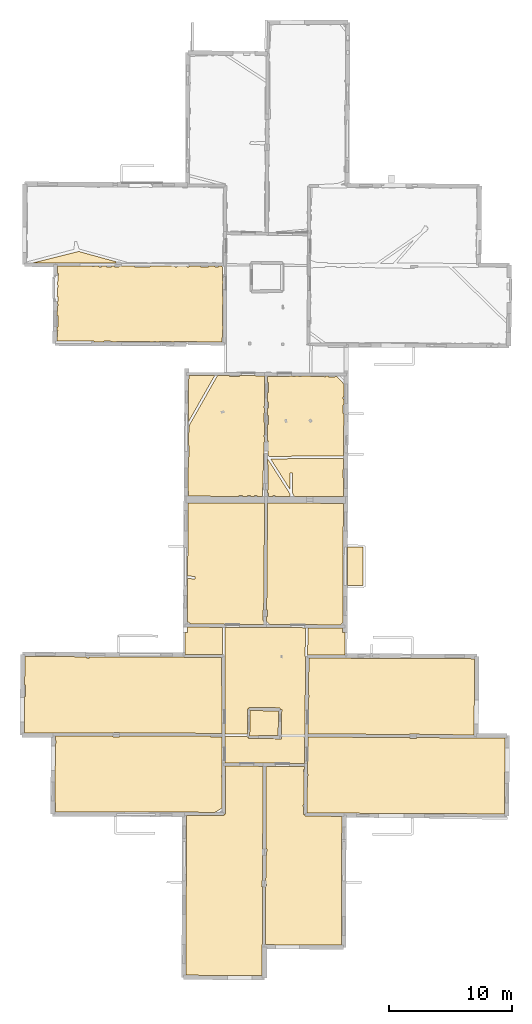
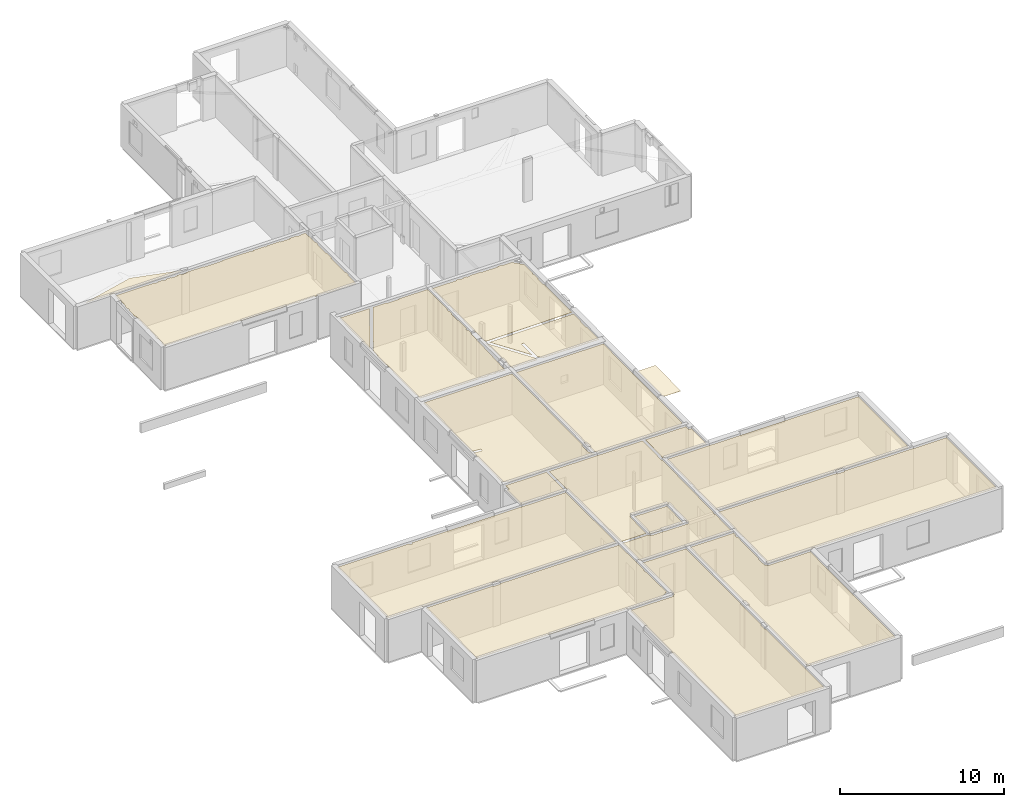
# One storey, part 12 of 17: 20 coverings.
"""IFC2X3 building model written with IfcOpenShell, lengths in metres."""

from ifc_helpers import new_model, entity, si_unit, converted_unit, derived_unit, direction, frame, origin, origin_with_axes, place, context, subcontext, project, spatial, polyline, outline, extrude, material, layer, layer_set, layer_usage, type_object, element, save


model = new_model("IFC2X3")

# Units and contexts
model_context = context("Model", 3, precision=1e-05, world=origin(), true_north=direction((0.0, 1.0)))
body_context = subcontext(model_context, "Body", "Model", "MODEL_VIEW")
ifc_project = project(units=[si_unit("LENGTHUNIT", "METRE"), si_unit("AREAUNIT", "SQUARE_METRE"), si_unit("VOLUMEUNIT", "CUBIC_METRE"), converted_unit("PLANEANGLEUNIT", "DEGREE", entity("IfcRatioMeasure", 0.0174532925199433), si_unit("PLANEANGLEUNIT", "RADIAN"), dimensions=[0, 0, 0, 0, 0, 0, 0]), si_unit("MASSUNIT", "GRAM", prefix="KILO"), derived_unit("MASSDENSITYUNIT", [(si_unit("MASSUNIT", "GRAM", prefix="KILO"), 1), (si_unit("LENGTHUNIT", "METRE"), -3)]), derived_unit("MOMENTOFINERTIAUNIT", [(si_unit("LENGTHUNIT", "METRE"), 4)]), si_unit("TIMEUNIT", "SECOND"), si_unit("FREQUENCYUNIT", "HERTZ"), si_unit("THERMODYNAMICTEMPERATUREUNIT", "DEGREE_CELSIUS"), derived_unit("THERMALTRANSMITTANCEUNIT", [(si_unit("MASSUNIT", "GRAM", prefix="KILO"), 1), (si_unit("THERMODYNAMICTEMPERATUREUNIT", "KELVIN"), -1), (si_unit("TIMEUNIT", "SECOND"), -3)]), derived_unit("VOLUMETRICFLOWRATEUNIT", [(si_unit("LENGTHUNIT", "METRE"), 3), (si_unit("TIMEUNIT", "SECOND"), -1)]), si_unit("ELECTRICCURRENTUNIT", "AMPERE"), si_unit("ELECTRICVOLTAGEUNIT", "VOLT"), si_unit("POWERUNIT", "WATT"), si_unit("FORCEUNIT", "NEWTON", prefix="KILO"), si_unit("ILLUMINANCEUNIT", "LUX"), si_unit("LUMINOUSFLUXUNIT", "LUMEN"), si_unit("LUMINOUSINTENSITYUNIT", "CANDELA"), derived_unit("USERDEFINED", [(si_unit("MASSUNIT", "GRAM", prefix="KILO"), -1), (si_unit("LENGTHUNIT", "METRE"), -2), (si_unit("TIMEUNIT", "SECOND"), 3), (si_unit("LUMINOUSFLUXUNIT", "LUMEN"), 1)]), derived_unit("LINEARVELOCITYUNIT", [(si_unit("LENGTHUNIT", "METRE"), 1), (si_unit("TIMEUNIT", "SECOND"), -1)]), si_unit("PRESSUREUNIT", "PASCAL"), derived_unit("USERDEFINED", [(si_unit("LENGTHUNIT", "METRE"), -2), (si_unit("MASSUNIT", "GRAM", prefix="KILO"), 1), (si_unit("TIMEUNIT", "SECOND"), -2)]), derived_unit("LINEARFORCEUNIT", [(si_unit("MASSUNIT", "GRAM", prefix="KILO"), 1), (si_unit("LENGTHUNIT", "METRE"), 1), (si_unit("TIMEUNIT", "SECOND"), -2), (si_unit("LENGTHUNIT", "METRE"), -1)]), derived_unit("PLANARFORCEUNIT", [(si_unit("MASSUNIT", "GRAM", prefix="KILO"), 1), (si_unit("LENGTHUNIT", "METRE"), 1), (si_unit("TIMEUNIT", "SECOND"), -2), (si_unit("LENGTHUNIT", "METRE"), -2)])], contexts=[model_context])

# Site, building, storey
placement = place(None, origin())
site = spatial("IfcSite", under=ifc_project, at=placement, CompositionType="ELEMENT")
building = spatial("IfcBuilding", under=site, at=placement, CompositionType="ELEMENT")
storey_placement = place(placement, frame((0.0, 0.0, 5.56662893295288)))
storey = spatial("IfcBuildingStorey", under=building, at=storey_placement, Name="Level 3", CompositionType="ELEMENT", Elevation=5.56662893295288)

# Coverings
ifc_material = material(Name="Covering default")
ifc_layer_1 = layer(ifc_material, 0.02)
ifc_layer_set_1 = layer_set([ifc_layer_1], Name="Covering : 20mm")
ifc_layer_usage_1 = layer_usage(ifc_layer_set_1, "AXIS3", "POSITIVE", 0.0)
covering_type_1 = type_object("IfcCoveringType", Name="Covering : 20mm", PredefinedType="CEILING")
covering_1_placement = place(placement, frame((0.0, 0.0, 8.5707950592041)))
element("IfcCovering", 1, at=covering_1_placement, inside=storey, type_object=covering_type_1, material=ifc_layer_usage_1, Name="Covering : 20mm", ObjectType="Covering : 20mm", PredefinedType="CEILING", context=body_context, shape_type="SweptSolid", body=[
    extrude(outline(polyline([(-0.158495903015137, 12.9272747039795), (2.870041847229, 12.9294729232788), (2.86995029449463, 13.0544738769531), (2.99994945526123, 13.0549507141113), (2.98575115203857, 16.9304695129395), (6.0559606552124, 16.915620803833), (6.01420116424561, 7.62759780883789), (5.95738506317139, 7.62850570678711), (5.94955539703369, 7.13856840133667), (6.01199817657471, 7.13757085800171), (5.98857402801514, 1.92784667015076), (5.98791980743408, -0.0800504088401794), (-0.209152221679688, -0.050336629152298), (-0.158495903015137, 12.9272747039795)])), origin_with_axes(), (0.0, 0.0, 1.0), 0.02),
])
ifc_layer_2 = layer(ifc_material, 0.02)
ifc_layer_set_2 = layer_set([ifc_layer_2], Name="Covering : 20mm")
ifc_layer_usage_2 = layer_usage(ifc_layer_set_2, "AXIS3", "POSITIVE", 0.0)
covering_type_2 = type_object("IfcCoveringType", Name="Covering : 20mm", PredefinedType="CEILING")
covering_2_placement = place(placement, frame((0.0, 0.0, 8.5707950592041)))
element("IfcCovering", 2, at=covering_2_placement, inside=storey, type_object=covering_type_2, material=ifc_layer_usage_2, Name="Covering : 20mm", ObjectType="Covering : 20mm", PredefinedType="CEILING", context=body_context, shape_type="SweptSolid", body=[
    extrude(outline(polyline([(6.27230358123779, 7.20511674880981), (6.32816600799561, 7.20514488220215), (6.32808399200439, 7.36514854431152), (6.27302265167236, 7.36512041091919), (6.28346347808838, 9.68734073638916), (6.35218334197998, 9.68637943267822), (6.35924625396729, 10.1913299560547), (6.28573513031006, 10.1923580169678), (6.31595706939697, 16.914363861084), (9.40763759613037, 16.8994083404541), (9.40445232391357, 16.6541633605957), (9.3533239364624, 16.6566944122314), (9.34342670440674, 16.456693649292), (9.40185070037842, 16.4538021087646), (9.3672456741333, 13.7889347076416), (9.31479549407959, 13.7866764068604), (9.34922695159912, 12.9871711730957), (9.45486354827881, 12.991720199585), (9.44913578033447, 12.9917945861816), (9.44857311248779, 12.8664751052856), (12.4514169692993, 12.8530235290527), (12.4169778823853, 2.39204859733582), (6.25081539154053, 2.42574691772461), (6.27230358123779, 7.20511674880981)])), origin_with_axes(), (0.0, 0.0, 1.0), 0.02),
])
ifc_layer_3 = layer(ifc_material, 0.02)
ifc_layer_set_3 = layer_set([ifc_layer_3], Name="Covering : 20mm")
ifc_layer_usage_3 = layer_usage(ifc_layer_set_3, "AXIS3", "POSITIVE", 0.0)
covering_type_3 = type_object("IfcCoveringType", Name="Covering : 20mm", PredefinedType="CEILING")
covering_3_placement = place(placement, frame((0.0, 0.0, 8.5707950592041)))
element("IfcCovering", 3, at=covering_3_placement, inside=storey, type_object=covering_type_3, material=ifc_layer_usage_3, Name="Covering : 20mm", ObjectType="Covering : 20mm", PredefinedType="CEILING", context=body_context, shape_type="SweptSolid", body=[
    extrude(outline(polyline([(9.65762615203857, 16.1268520355225), (9.71359539031982, 16.126880645752), (9.71351528167725, 16.2868804931641), (9.65970516204834, 16.2868518829346), (9.67087459564209, 17.1470699310303), (9.67087459564209, 17.1470699310303), (9.69874286651611, 19.293176651001), (17.9931602478027, 19.2454681396484), (17.9925880432129, 19.1877975463867), (18.5025634765625, 19.1827526092529), (18.5031547546387, 19.2425346374512), (23.3761177062988, 19.214506149292), (23.3761444091797, 19.2014865875244), (25.6997146606445, 19.2062892913818), (25.6643981933594, 13.0456771850586), (12.6374959945679, 13.1063585281372), (12.6374769210815, 13.1021928787231), (9.61852550506592, 13.1157159805298), (9.65762615203857, 16.1268520355225)])), origin_with_axes(), (0.0, 0.0, 1.0), 0.02),
])
ifc_layer_4 = layer(ifc_material, 0.02)
ifc_layer_set_4 = layer_set([ifc_layer_4], Name="Covering : 20mm")
ifc_layer_usage_4 = layer_usage(ifc_layer_set_4, "AXIS3", "POSITIVE", 0.0)
covering_type_4 = type_object("IfcCoveringType", Name="Covering : 20mm", PredefinedType="CEILING")
covering_4_placement = place(placement, frame((0.0, 0.0, 8.5707950592041)))
element("IfcCovering", 4, at=covering_4_placement, inside=storey, type_object=covering_type_4, material=ifc_layer_usage_4, Name="Covering : 20mm", ObjectType="Covering : 20mm", PredefinedType="CEILING", context=body_context, shape_type="SweptSolid", body=[
    extrude(outline(polyline([(-10.8086032867432, 18.7683277130127), (-10.7577590942383, 18.7663974761963), (-10.7478923797607, 19.0264015197754), (-10.807074546814, 19.0286464691162), (-10.8050508499146, 19.3731346130371), (-6.11005687713623, 19.3665676116943), (-6.1105260848999, 19.312816619873), (-5.59554576873779, 19.3083229064941), (-5.59504413604736, 19.3658466339111), (1.7731237411499, 19.3555374145508), (1.77196788787842, 19.3028144836426), (2.71713542938232, 19.2820587158203), (2.72483348846436, 17.1806201934814), (2.72483348846436, 17.1806201934814), (2.72837734222412, 16.2133026123047), (2.67355251312256, 16.2132740020752), (2.67364978790283, 16.0232753753662), (2.7290735244751, 16.0233039855957), (2.73818302154541, 13.5367527008057), (2.16902923583984, 13.1789646148682), (-10.7849082946777, 13.2056856155396), (-10.7852993011475, 13.9663791656494), (-10.8368139266968, 13.9663524627686), (-10.8086032867432, 18.7683277130127)])), origin_with_axes(), (0.0, 0.0, 1.0), 0.02),
])
ifc_layer_5 = layer(ifc_material, 0.02)
ifc_layer_set_5 = layer_set([ifc_layer_5], Name="Covering : 20mm")
ifc_layer_usage_5 = layer_usage(ifc_layer_set_5, "AXIS3", "POSITIVE", 0.0)
covering_type_5 = type_object("IfcCoveringType", Name="Covering : 20mm", PredefinedType="CEILING")
covering_5_placement = place(placement, frame((0.0, 0.0, 8.5707950592041)))
element("IfcCovering", 5, at=covering_5_placement, inside=storey, type_object=covering_type_5, material=ifc_layer_usage_5, Name="Covering : 20mm", ObjectType="Covering : 20mm", PredefinedType="CEILING", context=body_context, shape_type="SweptSolid", body=[
    extrude(outline(polyline([(2.95767498016357, 28.198522567749), (6.47996044158936, 28.1796741485596), (9.508376121521, 28.1634693145752), (9.47066974639893, 25.8293075561523), (9.52358341217041, 25.8284530639648), (9.4403600692749, 19.4194049835205), (9.381911277771, 19.419376373291), (9.38199901580811, 19.2467098236084), (9.43811893463135, 19.2467384338379), (9.41088390350342, 17.1493949890137), (6.05712795257568, 17.1656169891357), (6.05712795257568, 17.1656169891357), (2.98483562469482, 17.1804752349854), (2.97691249847412, 19.3432579040527), (4.77200603485107, 19.3406238555908), (4.77137660980225, 19.2836322784424), (4.87137126922607, 19.282527923584), (4.86987400054932, 19.1825389862061), (7.55145359039307, 19.1424236297607), (7.55444622039795, 19.3424015045166), (7.5374059677124, 19.3426570892334), (7.57736110687256, 21.5297183990479), (7.44738292694092, 21.5320930480957), (7.44945049285889, 21.6620769500732), (4.89870548248291, 21.7026386260986), (4.89663791656494, 21.5726547241211), (4.79664516448975, 21.5737571716309), (4.77421283721924, 19.5406188964844), (2.97618007659912, 19.5432567596436), (2.95058536529541, 26.5304126739502), (2.95767498016357, 28.198522567749)])), origin_with_axes(), (0.0, 0.0, 1.0), 0.02),
])
ifc_layer_6 = layer(ifc_material, 0.02)
ifc_layer_set_6 = layer_set([ifc_layer_6], Name="Covering : 20mm")
ifc_layer_usage_6 = layer_usage(ifc_layer_set_6, "AXIS3", "POSITIVE", 0.0)
covering_type_6 = type_object("IfcCoveringType", Name="Covering : 20mm", PredefinedType="CEILING")
covering_6_placement = place(placement, frame((0.0, 0.0, 8.5707950592041)))
element("IfcCovering", 6, at=covering_6_placement, inside=storey, type_object=covering_type_6, material=ifc_layer_usage_6, Name="Covering : 20mm", ObjectType="Covering : 20mm", PredefinedType="CEILING", context=body_context, shape_type="SweptSolid", body=[
    extrude(outline(polyline([(4.995192527771, 21.4410705566406), (7.31502437591553, 21.4041805267334), (7.27849864959717, 19.4048385620117), (5.69967746734619, 19.4292087554932), (5.69876575469971, 19.3701610565186), (4.97246265411377, 19.3810272216797), (4.995192527771, 21.4410705566406)])), origin_with_axes(), (0.0, 0.0, 1.0), 0.02),
])
ifc_layer_7 = layer(ifc_material, 0.02)
ifc_layer_set_7 = layer_set([ifc_layer_7], Name="Covering : 20mm")
ifc_layer_usage_7 = layer_usage(ifc_layer_set_7, "AXIS3", "POSITIVE", 0.0)
covering_type_7 = type_object("IfcCoveringType", Name="Covering : 20mm", PredefinedType="CEILING")
covering_7_placement = place(placement, frame((0.0, 0.0, 8.5707950592041)))
element("IfcCovering", 7, at=covering_7_placement, inside=storey, type_object=covering_type_7, material=ifc_layer_usage_7, Name="Covering : 20mm", ObjectType="Covering : 20mm", PredefinedType="CEILING", context=body_context, shape_type="SweptSolid", body=[
    extrude(outline(polyline([(9.74060344696045, 22.5168952941895), (9.80032253265381, 22.5169258117676), (9.80023097991943, 22.6969261169434), (9.74294185638428, 22.6968975067139), (9.78196620941162, 25.7021980285645), (23.2324485778809, 25.6460094451904), (23.1912422180176, 19.4655742645264), (18.7512435913086, 19.4911117553711), (18.7518501281738, 19.5415115356445), (17.9518432617188, 19.5510997772217), (17.9511795043945, 19.4957141876221), (9.70198726654053, 19.5431613922119), (9.74060344696045, 22.5168952941895)])), origin_with_axes(), (0.0, 0.0, 1.0), 0.02),
])
ifc_layer_8 = layer(ifc_material, 0.02)
ifc_layer_set_8 = layer_set([ifc_layer_8], Name="Covering : 20mm")
ifc_layer_usage_8 = layer_usage(ifc_layer_set_8, "AXIS3", "POSITIVE", 0.0)
covering_type_8 = type_object("IfcCoveringType", Name="Covering : 20mm", PredefinedType="CEILING")
covering_8_placement = place(placement, frame((0.0, 0.0, 8.5707950592041)))
element("IfcCovering", 8, at=covering_8_placement, inside=storey, type_object=covering_type_8, material=ifc_layer_usage_8, Name="Covering : 20mm", ObjectType="Covering : 20mm", PredefinedType="CEILING", context=body_context, shape_type="SweptSolid", body=[
    extrude(outline(polyline([(-13.304892539978, 22.5856857299805), (-13.2497158050537, 22.5851211547852), (-13.2401905059814, 23.5151271820068), (-13.2998647689819, 23.5157375335693), (-13.2873764038086, 25.8257789611816), (-8.29083633422852, 25.8057594299316), (-8.29824542999268, 25.7014770507812), (-8.09874820709229, 25.6873054504395), (-8.09038925170898, 25.8049564361572), (-0.375921249389648, 25.7740459442139), (-0.376006126403809, 25.7623138427734), (2.69347858428955, 25.7400054931641), (2.71599292755127, 19.5942192077637), (-5.60818767547607, 19.6058654785156), (-5.60821437835693, 19.6590347290039), (-6.0982141494751, 19.6587829589844), (-6.09818744659424, 19.6065502166748), (-10.9844303131104, 19.6133861541748), (-10.9844236373901, 19.6184482574463), (-13.3209171295166, 19.6213302612305), (-13.304892539978, 22.5856857299805)])), origin_with_axes(), (0.0, 0.0, 1.0), 0.02),
])
ifc_layer_9 = layer(ifc_material, 0.02)
ifc_layer_set_9 = layer_set([ifc_layer_9], Name="Covering : 20mm")
ifc_layer_usage_9 = layer_usage(ifc_layer_set_9, "AXIS3", "POSITIVE", 0.0)
covering_type_9 = type_object("IfcCoveringType", Name="Covering : 20mm", PredefinedType="CEILING")
covering_9_placement = place(placement, frame((0.0, 0.0, 8.5707950592041)))
element("IfcCovering", 9, at=covering_9_placement, inside=storey, type_object=covering_type_9, material=ifc_layer_usage_9, Name="Covering : 20mm", ObjectType="Covering : 20mm", PredefinedType="CEILING", context=body_context, shape_type="SweptSolid", body=[
    extrude(outline(polyline([(9.70838642120361, 28.1623992919922), (12.5280599594116, 28.1473121643066), (12.5263242721558, 27.796480178833), (12.7163228988647, 27.795539855957), (12.70716381073, 25.9453525543213), (9.67268466949463, 25.9524555206299), (9.70838642120361, 28.1623992919922)])), origin_with_axes(), (0.0, 0.0, 1.0), 0.02),
])
ifc_layer_10 = layer(ifc_material, 0.02)
ifc_layer_set_10 = layer_set([ifc_layer_10], Name="Covering : 20mm")
ifc_layer_usage_10 = layer_usage(ifc_layer_set_10, "AXIS3", "POSITIVE", 0.0)
covering_type_10 = type_object("IfcCoveringType", Name="Covering : 20mm", PredefinedType="CEILING")
covering_10_placement = place(placement, frame((0.0, 0.0, 8.5707950592041)))
element("IfcCovering", 10, at=covering_10_placement, inside=storey, type_object=covering_type_10, material=ifc_layer_usage_10, Name="Covering : 20mm", ObjectType="Covering : 20mm", PredefinedType="CEILING", context=body_context, shape_type="SweptSolid", body=[
    extrude(outline(polyline([(-0.284433364868164, 27.773265838623), (-0.0944366455078125, 27.7721920013428), (-0.0919342041015625, 28.2148399353027), (2.75767803192139, 28.199592590332), (2.74828433990479, 25.989616394043), (-0.294393539428711, 26.0117282867432), (-0.284433364868164, 27.773265838623)])), origin_with_axes(), (0.0, 0.0, 1.0), 0.02),
])
ifc_layer_11 = layer(ifc_material, 0.02)
ifc_layer_set_11 = layer_set([ifc_layer_11], Name="Covering : 20mm")
ifc_layer_usage_11 = layer_usage(ifc_layer_set_11, "AXIS3", "POSITIVE", 0.0)
covering_type_11 = type_object("IfcCoveringType", Name="Covering : 20mm", PredefinedType="CEILING")
covering_11_placement = place(placement, frame((0.0, 0.0, 8.5707950592041)))
element("IfcCovering", 11, at=covering_11_placement, inside=storey, type_object=covering_type_11, material=ifc_layer_usage_11, Name="Covering : 20mm", ObjectType="Covering : 20mm", PredefinedType="CEILING", context=body_context, shape_type="SweptSolid", body=[
    extrude(outline(polyline([(6.579421043396, 28.4291458129883), (12.3175363540649, 28.3984413146973), (12.5303564071655, 28.6114807128906), (12.5781488418579, 38.2692260742188), (6.42275905609131, 38.2888793945312), (6.3478536605835, 29.6037197113037), (6.39948749542236, 29.604621887207), (6.40856456756592, 29.0847015380859), (6.34336757659912, 29.0835628509521), (6.33994388580322, 28.6867733001709), (6.579421043396, 28.4291458129883)])), origin_with_axes(), (0.0, 0.0, 1.0), 0.02),
])
ifc_layer_12 = layer(ifc_material, 0.02)
ifc_layer_set_12 = layer_set([ifc_layer_12], Name="Covering : 20mm")
ifc_layer_usage_12 = layer_usage(ifc_layer_set_12, "AXIS3", "POSITIVE", 0.0)
covering_type_12 = type_object("IfcCoveringType", Name="Covering : 20mm", PredefinedType="CEILING")
covering_12_placement = place(placement, frame((0.0, 0.0, 8.5707950592041)))
element("IfcCovering", 12, at=covering_12_placement, inside=storey, type_object=covering_type_12, material=ifc_layer_usage_12, Name="Covering : 20mm", ObjectType="Covering : 20mm", PredefinedType="CEILING", context=body_context, shape_type="SweptSolid", body=[
    extrude(outline(polyline([(-0.0695114135742188, 32.1805229187012), (0.507436752319336, 32.1156806945801), (0.529773712158203, 32.3144302368164), (-0.0683746337890625, 32.3816566467285), (-0.0348587036132812, 38.3094902038574), (6.18275547027588, 38.2896461486816), (6.10775852203369, 29.59401512146), (6.05669689178467, 29.5950107574463), (6.040358543396, 28.7565803527832), (6.10052585601807, 28.755407333374), (6.09979152679443, 28.6701908111572), (6.21978282928467, 28.6691570281982), (6.1465425491333, 28.6010761260986), (6.3049955368042, 28.4306125640869), (0.253556251525879, 28.4629955291748), (-0.0894546508789062, 28.6533241271973), (-0.0695114135742188, 32.1805229187012)])), origin_with_axes(), (0.0, 0.0, 1.0), 0.02),
])
ifc_layer_13 = layer(ifc_material, 0.02)
ifc_layer_set_13 = layer_set([ifc_layer_13], Name="Covering : 20mm")
ifc_layer_usage_13 = layer_usage(ifc_layer_set_13, "AXIS3", "POSITIVE", 0.0)
covering_type_13 = type_object("IfcCoveringType", Name="Covering : 20mm", PredefinedType="CEILING")
covering_13_placement = place(placement, frame((0.0, 0.0, 8.5707950592041)))
element("IfcCovering", 13, at=covering_13_placement, inside=storey, type_object=covering_type_13, material=ifc_layer_usage_13, Name="Covering : 20mm", ObjectType="Covering : 20mm", PredefinedType="CEILING", context=body_context, shape_type="SweptSolid", body=[
    extrude(outline(polyline([(12.9305372238159, 34.7093887329102), (14.1855802536011, 34.7027244567871), (14.1625547409058, 31.5873718261719), (12.9151239395142, 31.5947151184082), (12.9305372238159, 34.7093887329102)])), origin_with_axes(), (0.0, 0.0, 1.0), 0.02),
])
ifc_layer_14 = layer(ifc_material, 0.02)
ifc_layer_set_14 = layer_set([ifc_layer_14], Name="Covering : 20mm")
ifc_layer_usage_14 = layer_usage(ifc_layer_set_14, "AXIS3", "POSITIVE", 0.0)
covering_type_14 = type_object("IfcCoveringType", Name="Covering : 20mm", PredefinedType="CEILING")
covering_14_placement = place(placement, frame((0.0, 0.0, 8.5707950592041)))
element("IfcCovering", 14, at=covering_14_placement, inside=storey, type_object=covering_type_14, material=ifc_layer_usage_14, Name="Covering : 20mm", ObjectType="Covering : 20mm", PredefinedType="CEILING", context=body_context, shape_type="SweptSolid", body=[
    extrude(outline(polyline([(8.23166370391846, 39.4223556518555), (8.23098659515381, 40.7461242675781), (8.43098545074463, 40.7462272644043), (8.43182468414307, 39.1075630187988), (8.61347484588623, 38.8218879699707), (12.5808210372925, 38.8092193603516), (12.5882844924927, 40.3175506591797), (12.5312070846558, 40.3183250427246), (12.5408430099487, 41.0283317565918), (12.5917997360229, 41.0276412963867), (12.5962591171265, 41.9288139343262), (6.67083644866943, 41.8770484924316), (8.23166370391846, 39.4223556518555)])), origin_with_axes(), (0.0, 0.0, 1.0), 0.02),
])
ifc_layer_15 = layer(ifc_material, 0.02)
ifc_layer_set_15 = layer_set([ifc_layer_15], Name="Covering : 20mm")
ifc_layer_usage_15 = layer_usage(ifc_layer_set_15, "AXIS3", "POSITIVE", 0.0)
covering_type_15 = type_object("IfcCoveringType", Name="Covering : 20mm", PredefinedType="CEILING")
covering_15_placement = place(placement, frame((0.0, 0.0, 8.5707950592041)))
element("IfcCovering", 15, at=covering_15_placement, inside=storey, type_object=covering_type_15, material=ifc_layer_usage_15, Name="Covering : 20mm", ObjectType="Covering : 20mm", PredefinedType="CEILING", context=body_context, shape_type="SweptSolid", body=[
    extrude(outline(polyline([(6.40727710723877, 41.9188041687012), (8.23185443878174, 39.04931640625), (8.23197078704834, 38.8231048583984), (7.03197002410889, 38.8269348144531), (7.03193950653076, 38.8855094909668), (6.85193920135498, 38.8854179382324), (6.85196781158447, 38.8275108337402), (6.4943265914917, 38.8286514282227), (6.48181629180908, 39.1252288818359), (6.42995357513428, 39.1230430603027), (6.43196392059326, 39.3561973571777), (6.46169376373291, 39.3652153015137), (6.46167087554932, 39.4105033874512), (6.46885395050049, 39.4105033874512), (6.46063899993896, 41.4252166748047), (6.40949535369873, 41.4251899719238), (6.40727710723877, 41.9188041687012)])), origin_with_axes(), (0.0, 0.0, 1.0), 0.02),
])
ifc_layer_16 = layer(ifc_material, 0.02)
ifc_layer_set_16 = layer_set([ifc_layer_16], Name="Covering : 20mm")
ifc_layer_usage_16 = layer_usage(ifc_layer_set_16, "AXIS3", "POSITIVE", 0.0)
covering_type_16 = type_object("IfcCoveringType", Name="Covering : 20mm", PredefinedType="CEILING")
covering_16_placement = place(placement, frame((0.0, 0.0, 8.5707950592041)))
element("IfcCovering", 16, at=covering_16_placement, inside=storey, type_object=covering_type_16, material=ifc_layer_usage_16, Name="Covering : 20mm", ObjectType="Covering : 20mm", PredefinedType="CEILING", context=body_context, shape_type="SweptSolid", body=[
    extrude(outline(polyline([(-0.0137519836425781, 42.0424919128418), (0.0403213500976562, 42.0419273376465), (0.0498552322387695, 42.9519348144531), (-0.00860691070556641, 42.9525451660156), (-0.00266647338867188, 44.0032806396484), (0.0493173599243164, 44.0019378662109), (0.0648059844970703, 44.6021575927734), (2.35587978363037, 48.6441116333008), (3.31694316864014, 48.6394844055176), (3.31697177886963, 48.5836067199707), (4.15697193145752, 48.5840377807617), (4.15694522857666, 48.6354446411133), (6.18753337860107, 48.625675201416), (6.18224048614502, 46.1650733947754), (6.12821102142334, 46.1650466918945), (6.12829303741455, 46.0050506591797), (6.18189716339111, 46.0050773620605), (6.18105792999268, 45.6150779724121), (6.128493309021, 45.6150512695312), (6.12889766693115, 44.8250503540039), (6.17935848236084, 44.8250770568848), (6.17720890045166, 43.8250732421875), (6.11940860748291, 43.8250427246094), (6.11950588226318, 43.6350402832031), (6.17679882049561, 43.6350708007812), (6.17593669891357, 43.2339897155762), (6.1397123336792, 43.2350540161133), (6.01032733917236, 38.8301963806152), (5.56196689605713, 38.8316307067871), (5.56194019317627, 38.8847579956055), (5.36193943023682, 38.8846549987793), (5.36196613311768, 38.8322677612305), (5.02196598052979, 38.8333511352539), (5.02193927764893, 38.8844795227051), (4.7919397354126, 38.8843612670898), (4.79196643829346, 38.8340873718262), (4.38196468353271, 38.8353958129883), (4.38193416595459, 38.8941535949707), (4.12193393707275, 38.8940200805664), (4.12196445465088, 38.8362274169922), (0.0219564437866211, 38.8493118286133), (0.0217447280883789, 39.2619209289551), (-0.0294733047485352, 39.2618942260742), (-0.0137519836425781, 42.0424919128418)])), origin_with_axes(), (0.0, 0.0, 1.0), 0.02),
])
ifc_layer_17 = layer(ifc_material, 0.02)
ifc_layer_set_17 = layer_set([ifc_layer_17], Name="Covering : 20mm")
ifc_layer_usage_17 = layer_usage(ifc_layer_set_17, "AXIS3", "POSITIVE", 0.0)
covering_type_17 = type_object("IfcCoveringType", Name="Covering : 20mm", PredefinedType="CEILING")
covering_17_placement = place(placement, frame((0.0, 0.0, 8.5707950592041)))
element("IfcCovering", 17, at=covering_17_placement, inside=storey, type_object=covering_type_17, material=ifc_layer_usage_17, Name="Covering : 20mm", ObjectType="Covering : 20mm", PredefinedType="CEILING", context=body_context, shape_type="SweptSolid", body=[
    extrude(outline(polyline([(6.42899417877197, 44.655200958252), (6.48898410797119, 44.6552314758301), (6.48860454559326, 45.3952331542969), (6.43058490753174, 45.3952026367188), (6.43189716339111, 46.0052032470703), (6.48829174041748, 46.0052337646484), (6.48804759979248, 46.4852333068848), (6.43292903900146, 46.4852066040039), (6.43460559844971, 47.2652053833008), (6.48764705657959, 47.2652320861816), (6.48723888397217, 48.0652313232422), (6.4363260269165, 48.0652046203613), (6.43740367889404, 48.5659332275391), (8.2069845199585, 48.5561141967773), (8.20731639862061, 48.6159553527832), (8.44695568084717, 48.614803314209), (8.44698619842529, 48.5562362670898), (8.7069845199585, 48.5563659667969), (8.706955909729, 48.6135520935059), (8.92695713043213, 48.612491607666), (8.92698574066162, 48.5564804077148), (9.16698360443115, 48.5566024780273), (9.16695499420166, 48.6113395690918), (9.91161441802979, 48.6077537536621), (9.91121768951416, 48.5569496154785), (11.1069898605347, 48.5475997924805), (11.1074151992798, 48.6020011901855), (11.3669652938843, 48.6007537841797), (11.3669919967651, 48.5477333068848), (12.0675706863403, 48.5480880737305), (12.6260824203491, 47.9559898376465), (12.6208982467651, 46.908374786377), (12.567831993103, 46.9083480834961), (12.5679121017456, 46.7483444213867), (12.6201066970825, 46.7483711242676), (12.6175832748413, 46.2383728027344), (12.5581731796265, 46.2383422851562), (12.5585203170776, 45.5635032653809), (12.6142435073853, 45.563533782959), (12.5972471237183, 42.1288299560547), (6.54436206817627, 42.0759506225586), (6.43777751922607, 42.243579864502), (6.47967052459717, 43.3152275085449), (6.42611789703369, 43.3173217773438), (6.42899417877197, 44.655200958252)])), origin_with_axes(), (0.0, 0.0, 1.0), 0.02),
])
ifc_layer_18 = layer(ifc_material, 0.02)
ifc_layer_set_18 = layer_set([ifc_layer_18], Name="Covering : 20mm")
ifc_layer_usage_18 = layer_usage(ifc_layer_set_18, "AXIS3", "POSITIVE", 0.0)
covering_type_18 = type_object("IfcCoveringType", Name="Covering : 20mm", PredefinedType="CEILING")
covering_18_placement = place(placement, frame((0.0, 0.0, 8.5707950592041)))
element("IfcCovering", 18, at=covering_18_placement, inside=storey, type_object=covering_type_18, material=ifc_layer_usage_18, Name="Covering : 20mm", ObjectType="Covering : 20mm", PredefinedType="CEILING", context=body_context, shape_type="SweptSolid", body=[
    extrude(outline(polyline([(0.0236368179321289, 48.655330657959), (2.12661075592041, 48.6452140808105), (0.00239086151123047, 44.8976249694824), (0.0236368179321289, 48.655330657959)])), origin_with_axes(), (0.0, 0.0, 1.0), 0.02),
])
ifc_layer_19 = layer(ifc_material, 0.02)
ifc_layer_set_19 = layer_set([ifc_layer_19], Name="Covering : 20mm")
ifc_layer_usage_19 = layer_usage(ifc_layer_set_19, "AXIS3", "POSITIVE", 0.0)
covering_type_19 = type_object("IfcCoveringType", Name="Covering : 20mm", PredefinedType="CEILING")
covering_19_placement = place(placement, frame((0.0, 0.0, 8.5707950592041)))
element("IfcCovering", 19, at=covering_19_placement, inside=storey, type_object=covering_type_19, material=ifc_layer_usage_19, Name="Covering : 20mm", ObjectType="Covering : 20mm", PredefinedType="CEILING", context=body_context, shape_type="SweptSolid", body=[
    extrude(outline(polyline([(-10.6771440505981, 51.7774124145508), (-10.6246643066406, 51.7764663696289), (-10.6149425506592, 52.3164749145508), (-10.6718645095825, 52.3175010681152), (-10.6690349578857, 52.6070289611816), (-10.6150913238525, 52.6064758300781), (-10.6055698394775, 53.5364799499512), (-10.6599435806274, 53.537036895752), (-10.6526184082031, 54.2864532470703), (-10.5959510803223, 54.2864837646484), (-10.5960388183594, 54.4564819335938), (-10.6509571075439, 54.4564552307129), (-10.6488056182861, 54.676456451416), (-10.6061534881592, 54.6764793395996), (-10.6063423156738, 55.0464782714844), (-10.6581020355225, 55.0464515686035), (-10.6493043899536, 55.7964553833008), (-10.5967254638672, 55.7964820861816), (-10.5968322753906, 56.0064849853516), (-10.6468410491943, 56.0064582824707), (-10.6436491012573, 56.2785797119141), (-10.5969696044922, 56.276481628418), (-10.567310333252, 56.9365005493164), (-10.6266889572144, 56.9391708374023), (-10.6207876205444, 57.542911529541), (-7.82761669158936, 57.5385475158691), (-7.8275899887085, 57.4878997802734), (-7.61759090423584, 57.4880104064941), (-7.61761713027954, 57.5382194519043), (-7.2576150894165, 57.537654876709), (-7.25758457183838, 57.4781951904297), (-7.04758548736572, 57.4783020019531), (-7.04761552810669, 57.5373268127441), (-6.67761611938477, 57.5367469787598), (-6.67758655548096, 57.4784927368164), (-6.26758670806885, 57.4786987304688), (-6.2676157951355, 57.5361099243164), (-5.99761486053467, 57.5356864929199), (-5.99758625030518, 57.4788398742676), (-5.62758541107178, 57.4790267944336), (-5.62761402130127, 57.5351066589355), (-4.38063621520996, 57.5331611633301), (-4.38060855865479, 57.479663848877), (-3.10758590698242, 57.4803199768066), (-3.10761165618896, 57.5311698913574), (-1.10760879516602, 57.5280456542969), (-1.10758113861084, 57.4713439941406), (-0.937581062316895, 57.4714279174805), (-0.93760871887207, 57.5277786254883), (-0.117609024047852, 57.526496887207), (-0.117581367492676, 57.471851348877), (0.0524187088012695, 57.4719390869141), (0.0523910522460938, 57.5262336730957), (0.972391128540039, 57.5247955322266), (0.972418785095215, 57.4724082946777), (1.62241840362549, 57.4727401733398), (1.62239170074463, 57.5237808227539), (2.15239238739014, 57.52294921875), (2.15242385864258, 57.4630126953125), (2.43242168426514, 57.4631576538086), (2.43239116668701, 57.5225143432617), (2.74081897735596, 57.522029876709), (2.7729959487915, 56.3433303833008), (2.82301998138428, 56.3446960449219), (2.82222843170166, 56.1133575439453), (2.7631139755249, 56.1133270263672), (2.76365184783936, 55.0633239746094), (2.81863307952881, 55.0633506774902), (2.8164758682251, 54.4330596923828), (2.7639741897583, 54.4333267211914), (2.75488567352295, 52.6533203125), (2.81038188934326, 52.6530380249023), (2.80945491790771, 52.3822364807129), (2.75502490997314, 52.3833198547363), (2.73446941375732, 51.3500938415527), (0.695862770080566, 51.363208770752), (0.695516586303711, 51.4222640991211), (-1.17447757720947, 51.4113082885742), (-1.17412853240967, 51.3517990112305), (-1.38444805145264, 51.3527870178223), (-1.38447761535645, 51.4112014770508), (-2.39447784423828, 51.4106826782227), (-2.39445018768311, 51.3575172424316), (-2.63445091247559, 51.358642578125), (-2.63447761535645, 51.4105606079102), (-2.8344783782959, 51.410457611084), (-2.83445262908936, 51.3595809936523), (-3.14467144012451, 51.3610343933105), (-3.14448356628418, 51.4202995300293), (-5.8544864654541, 51.4289093017578), (-5.85466194152832, 51.3737297058105), (-6.18525648117065, 51.3752784729004), (-6.18448638916016, 51.4287414550781), (-6.85449314117432, 51.4384002685547), (-6.85535764694214, 51.37841796875), (-7.67465734481812, 51.3822593688965), (-7.67449283599854, 51.4379806518555), (-10.6803750991821, 51.4468765258789), (-10.6771440505981, 51.7774124145508)])), origin_with_axes(), (0.0, 0.0, 1.0), 0.02),
])
ifc_layer_20 = layer(ifc_material, 0.02)
ifc_layer_set_20 = layer_set([ifc_layer_20], Name="Covering : 20mm")
ifc_layer_usage_20 = layer_usage(ifc_layer_set_20, "AXIS3", "POSITIVE", 0.0)
covering_type_20 = type_object("IfcCoveringType", Name="Covering : 20mm", PredefinedType="CEILING")
covering_20_placement = place(placement, frame((0.0, 0.0, 8.5707950592041)))
element("IfcCovering", 20, at=covering_20_placement, inside=storey, type_object=covering_type_20, material=ifc_layer_usage_20, Name="Covering : 20mm", ObjectType="Covering : 20mm", PredefinedType="CEILING", context=body_context, shape_type="SweptSolid", body=[
    extrude(outline(polyline([(-12.6038074493408, 57.8002853393555), (-8.91740322113037, 58.7238960266113), (-5.74395179748535, 57.850959777832), (-5.87700414657593, 57.8536376953125), (-5.87837553024292, 57.7854995727539), (-10.7939872741699, 57.7931823730469), (-10.7940082550049, 57.7896575927734), (-12.6038074493408, 57.8002853393555)])), origin_with_axes(), (0.0, 0.0, 1.0), 0.02),
])

save(model, "model.ifc")
